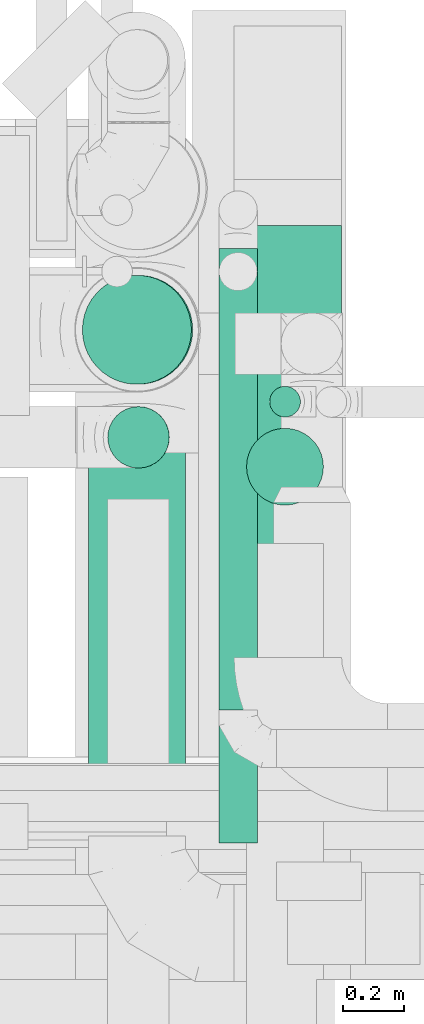
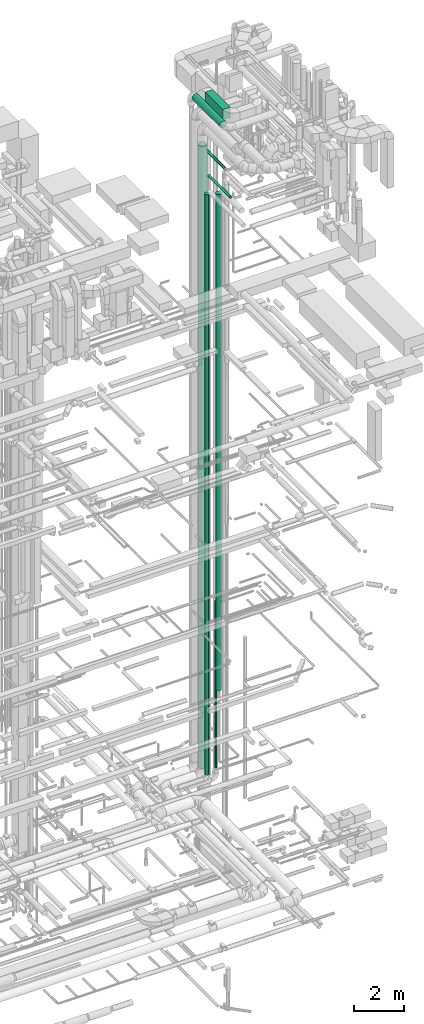
# One storey, part 64 of 337: 8 flow segments.
"""IFC2X3 building model written with IfcOpenShell, lengths in millimetres."""

from ifc_helpers import new_model, entity, si_unit, converted_unit, derived_unit, direction, frame, origin, origin_2d_with_axis, place, context, subcontext, project, spatial, rectangle, circle, extrude, type_object, element, save


model = new_model("IFC2X3")

# Units and contexts
model_context = context("Model", 3, precision=0.01, world=origin(), true_north=direction((6.12303176911189e-17, 1.0)))
body_context = subcontext(model_context, "Body", "Model", "MODEL_VIEW")
ifc_project = project(units=[si_unit("LENGTHUNIT", "METRE", prefix="MILLI"), si_unit("AREAUNIT", "SQUARE_METRE"), si_unit("VOLUMEUNIT", "CUBIC_METRE"), converted_unit("PLANEANGLEUNIT", "DEGREE", entity("IfcRatioMeasure", 0.0174532925199433), si_unit("PLANEANGLEUNIT", "RADIAN"), dimensions=[0, 0, 0, 0, 0, 0, 0]), si_unit("MASSUNIT", "GRAM", prefix="KILO"), derived_unit("MASSDENSITYUNIT", [(si_unit("MASSUNIT", "GRAM", prefix="KILO"), 1), (si_unit("LENGTHUNIT", "METRE"), -3)]), derived_unit("MOMENTOFINERTIAUNIT", [(si_unit("LENGTHUNIT", "METRE"), 4)]), si_unit("TIMEUNIT", "SECOND"), si_unit("FREQUENCYUNIT", "HERTZ"), si_unit("THERMODYNAMICTEMPERATUREUNIT", "DEGREE_CELSIUS"), derived_unit("THERMALTRANSMITTANCEUNIT", [(si_unit("MASSUNIT", "GRAM", prefix="KILO"), 1), (si_unit("THERMODYNAMICTEMPERATUREUNIT", "KELVIN"), -1), (si_unit("TIMEUNIT", "SECOND"), -3)]), derived_unit("VOLUMETRICFLOWRATEUNIT", [(si_unit("LENGTHUNIT", "METRE"), 3), (si_unit("TIMEUNIT", "SECOND"), -1)]), derived_unit("MASSFLOWRATEUNIT", [(si_unit("MASSUNIT", "GRAM", prefix="KILO"), 1), (si_unit("TIMEUNIT", "SECOND"), -1)]), derived_unit("ROTATIONALFREQUENCYUNIT", [(si_unit("TIMEUNIT", "SECOND"), -1)]), si_unit("ELECTRICCURRENTUNIT", "AMPERE"), si_unit("ELECTRICVOLTAGEUNIT", "VOLT"), si_unit("POWERUNIT", "WATT"), si_unit("FORCEUNIT", "NEWTON", prefix="KILO"), si_unit("ILLUMINANCEUNIT", "LUX"), si_unit("LUMINOUSFLUXUNIT", "LUMEN"), si_unit("LUMINOUSINTENSITYUNIT", "CANDELA"), derived_unit("USERDEFINED", [(si_unit("MASSUNIT", "GRAM", prefix="KILO"), -1), (si_unit("LENGTHUNIT", "METRE"), -2), (si_unit("TIMEUNIT", "SECOND"), 3), (si_unit("LUMINOUSFLUXUNIT", "LUMEN"), 1)]), derived_unit("LINEARVELOCITYUNIT", [(si_unit("LENGTHUNIT", "METRE"), 1), (si_unit("TIMEUNIT", "SECOND"), -1)]), si_unit("PRESSUREUNIT", "PASCAL"), derived_unit("USERDEFINED", [(si_unit("LENGTHUNIT", "METRE"), -2), (si_unit("MASSUNIT", "GRAM", prefix="KILO"), 1), (si_unit("TIMEUNIT", "SECOND"), -2)]), derived_unit("LINEARFORCEUNIT", [(si_unit("MASSUNIT", "GRAM", prefix="KILO"), 1), (si_unit("LENGTHUNIT", "METRE"), 1), (si_unit("TIMEUNIT", "SECOND"), -2), (si_unit("LENGTHUNIT", "METRE"), -1)]), derived_unit("PLANARFORCEUNIT", [(si_unit("MASSUNIT", "GRAM", prefix="KILO"), 1), (si_unit("LENGTHUNIT", "METRE"), 1), (si_unit("TIMEUNIT", "SECOND"), -2), (si_unit("LENGTHUNIT", "METRE"), -2)])], contexts=[model_context])

# Site, building, storey
site_placement = place(None, origin())
site = spatial("IfcSite", under=ifc_project, at=site_placement, CompositionType="ELEMENT")
building_placement = place(site_placement, origin())
building = spatial("IfcBuilding", under=site, at=building_placement, CompositionType="ELEMENT")
storey_placement = place(building_placement, origin())
storey = spatial("IfcBuildingStorey", under=building, at=storey_placement, CompositionType="ELEMENT", Elevation=0.0)

# Flow segments
duct_segment_type_1 = type_object("IfcDuctSegmentType", PredefinedType="NOTDEFINED")
flow_segment_1_placement = place(storey_placement, frame((67874.87, 10723.58, 35280.0)))
element("IfcFlowSegment", 1, at=flow_segment_1_placement, inside=storey, type_object=duct_segment_type_1, context=body_context, shape_type="SweptSolid", body=[
    extrude(rectangle(XDim=1404.46798999995, YDim=349.999999999998, at=origin_2d_with_axis()), frame((175.0, 702.23, 0.0), z_axis=(0.0, 0.0, 1.0), x_axis=(0.0, -1.0, 0.0)), (0.0, 0.0, 1.0), 499.999999999999),
])
duct_segment_type_2 = type_object("IfcDuctSegmentType", PredefinedType="NOTDEFINED")
flow_segment_2_placement = place(storey_placement, frame((67989.23, 11503.66, 3320.0)))
element("IfcFlowSegment", 2, at=flow_segment_2_placement, inside=storey, type_object=duct_segment_type_2, context=body_context, shape_type="SweptSolid", body=[
    extrude(circle(Radius=50.0, at=origin_2d_with_axis()), frame((51.6, 51.6, 0.0), z_axis=(0.0, 0.0, 1.0), x_axis=(0.0, 1.0, 0.0)), (0.0, 0.0, 1.0), 8080.00000000001),
])
flow_segment_3_placement = place(storey_placement, frame((67399.96, 10142.35, 35360.9)))
element("IfcFlowSegment", 3, at=flow_segment_3_placement, inside=storey, type_object=duct_segment_type_2, context=body_context, shape_type="SweptSolid", body=[
    extrude(circle(Radius=157.5, at=origin_2d_with_axis()), frame((159.1, 0.0, 159.1), z_axis=(0.0, 1.0, 0.0), x_axis=(1.0, 0.0, 0.0)), (0.0, 0.0, 1.0), 2208.45261933983),
])
flow_segment_4_placement = place(storey_placement, frame((67823.9, 10552.27, 32950.9)))
element("IfcFlowSegment", 4, at=flow_segment_4_placement, inside=storey, type_object=duct_segment_type_2, context=body_context, shape_type="SweptSolid", body=[
    extrude(circle(Radius=62.5, at=origin_2d_with_axis()), frame((64.1, 0.0, 64.1), z_axis=(0.0, 1.0, 0.0), x_axis=(1.0, 0.0, 0.0)), (0.0, 0.0, 1.0), 1501.47116017033),
])
flow_segment_5_placement = place(storey_placement, frame((67913.98, 11217.12, 7250.0)))
element("IfcFlowSegment", 5, at=flow_segment_5_placement, inside=storey, type_object=duct_segment_type_2, context=body_context, shape_type="SweptSolid", body=[
    extrude(circle(Radius=125.0, at=origin_2d_with_axis()), frame((126.6, 126.6, 0.0)), (0.0, 0.0, 1.0), 24075.0),
])
flow_segment_6_placement = place(storey_placement, frame((67823.9, 10120.25, 31825.9)))
element("IfcFlowSegment", 6, at=flow_segment_6_placement, inside=storey, type_object=duct_segment_type_2, context=body_context, shape_type="SweptSolid", body=[
    extrude(circle(Radius=62.5, at=origin_2d_with_axis()), frame((64.1, 0.0, 64.1), z_axis=(0.0, 1.0, 0.0), x_axis=(1.0, 0.0, 0.0)), (0.0, 0.0, 1.0), 1733.29076593382),
])
flow_segment_7_placement = place(storey_placement, frame((67379.95, 11610.06, 3405.02)))
element("IfcFlowSegment", 7, at=flow_segment_7_placement, inside=storey, type_object=duct_segment_type_2, context=body_context, shape_type="SweptSolid", body=[
    extrude(circle(Radius=177.5, at=origin_2d_with_axis()), frame((183.23, 179.1, 0.02), z_axis=(-0.000136960044590436, 0.0, 0.999999990620973), x_axis=(-0.999999990620973, 0.0, -0.000136960044590436)), (0.0, 0.0, 1.0), 30179.9517342104),
])
flow_segment_8_placement = place(storey_placement, frame((67462.46, 11337.75, 3250.0)))
element("IfcFlowSegment", 8, at=flow_segment_8_placement, inside=storey, type_object=duct_segment_type_2, context=body_context, shape_type="SweptSolid", body=[
    extrude(circle(Radius=100.0, at=origin_2d_with_axis()), frame((101.9, 101.6, 0.0), z_axis=(-1.06735978174208e-05, 0.0, 1.0), x_axis=(0.0, -1.0, 0.0)), (0.0, 0.0, 1.0), 28149.9978516202),
])

save(model, "model.ifc")
